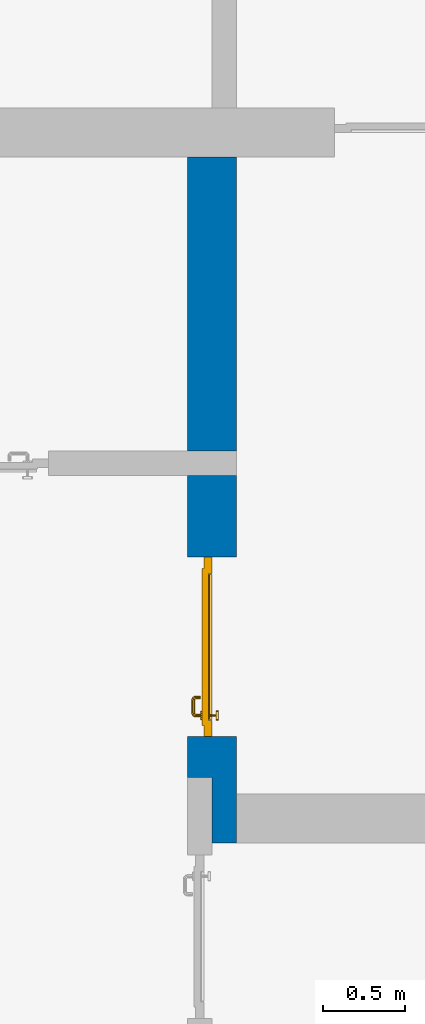
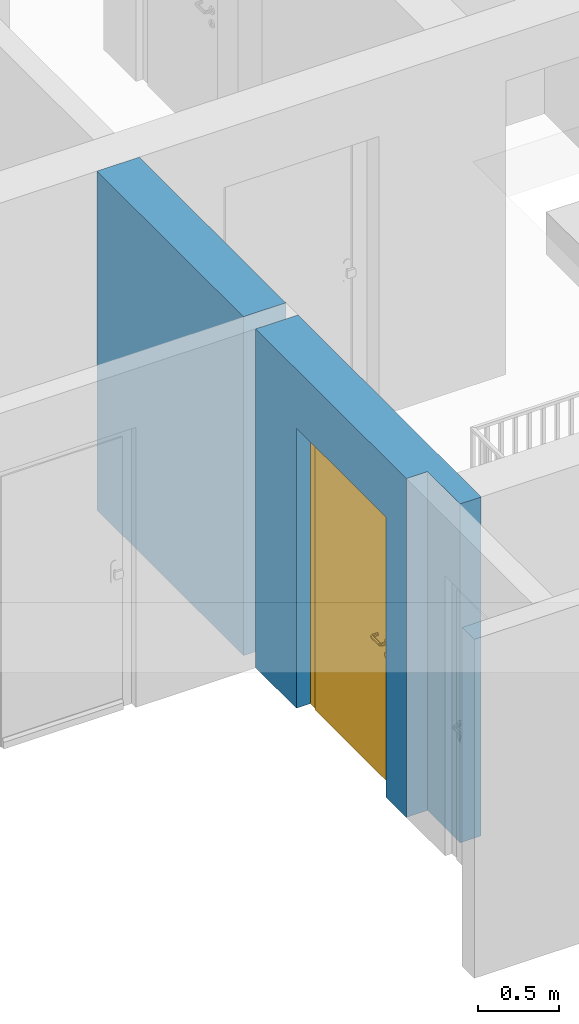
# One storey, part 10 of 48: 1 door, 1 wall, 1 opening.
"""IFC4 building model written with IfcOpenShell, lengths in metres."""

from ifc_helpers import new_model, entity, si_unit, converted_unit, derived_unit, direction, frame, origin_with_axes, place, context, subcontext, project, spatial, polygons, source, transform, mapped, material, type_object, element, fill, save


model = new_model("IFC4")

# Units and contexts
model_context = context("Model", 3, precision=1e-05, world=origin_with_axes(), true_north=direction((0.0, 1.0)))
body_context = subcontext(model_context, "Body", "Model", "MODEL_VIEW")
ifc_project = project(units=[si_unit("LENGTHUNIT", "METRE"), si_unit("AREAUNIT", "SQUARE_METRE"), si_unit("VOLUMEUNIT", "CUBIC_METRE"), converted_unit("PLANEANGLEUNIT", "DEGREE", entity("IfcPlaneAngleMeasure", 0.0174532925199), si_unit("PLANEANGLEUNIT", "RADIAN"), dimensions=[0, 0, 0, 0, 0, 0, 0]), converted_unit("TIMEUNIT", "Year", entity("IfcTimeMeasure", 31556926.0), si_unit("TIMEUNIT", "SECOND"), dimensions=[0, 0, 1, 0, 0, 0, 0]), si_unit("MASSUNIT", "GRAM", prefix="KILO"), si_unit("THERMODYNAMICTEMPERATUREUNIT", "DEGREE_CELSIUS"), si_unit("LUMINOUSINTENSITYUNIT", "LUMEN"), si_unit("ENERGYUNIT", "JOULE", prefix="MEGA"), derived_unit("THERMALCONDUCTANCEUNIT", [(si_unit("POWERUNIT", "WATT"), 1), (si_unit("LENGTHUNIT", "METRE"), -1), (si_unit("THERMODYNAMICTEMPERATUREUNIT", "KELVIN"), -1)]), derived_unit("SPECIFICHEATCAPACITYUNIT", [(si_unit("ENERGYUNIT", "JOULE"), 1), (si_unit("MASSUNIT", "GRAM", prefix="KILO"), -1), (si_unit("THERMODYNAMICTEMPERATUREUNIT", "KELVIN"), -1)]), derived_unit("MASSDENSITYUNIT", [(si_unit("MASSUNIT", "GRAM", prefix="KILO"), 1), (si_unit("VOLUMEUNIT", "CUBIC_METRE"), -1)])], contexts=[model_context])

# Site, building, storey
site_placement = place(None, origin_with_axes())
site = spatial("IfcSite", under=ifc_project, at=site_placement, CompositionType="ELEMENT")
building_placement = place(site_placement, origin_with_axes())
building = spatial("IfcBuilding", under=site, at=building_placement, CompositionType="ELEMENT")
storey_placement = place(building_placement, frame((0.0, 0.0, 3.4), z_axis=(0.0, 0.0, 1.0), x_axis=(1.0, 0.0, 0.0)))
storey = spatial("IfcBuildingStorey", under=building, at=storey_placement, Name="1. Geschoss", CompositionType="ELEMENT", Elevation=3.4)

# Wall, opening, door
ifc_material = material()
wall_type = type_object("IfcWallType", Name="300", PredefinedType="NOTDEFINED")
wall_placement = place(storey_placement, frame((-5.2421993804, -2.52881223104, 0.0), z_axis=(0.0, 0.0, 1.0), x_axis=(0.0, 1.0, 0.0)))
wall = element("IfcWall", 1, at=wall_placement, inside=storey, type_object=wall_type, material=ifc_material, Name="Wand-001", PredefinedType="NOTDEFINED", context=body_context, shape_type="Tessellation", body=[
    polygons([(0.35, -0.15, 2.1), (1.45, -0.15, 2.1), (1.45, -0.3, 2.1), (0.35, -0.3, 2.1), (0.35, 0.0, 2.1), (1.45, 0.0, 2.1), (1.45, -0.15, 0.0), (1.45, -0.3, 0.0), (1.95, -0.3, 2.54), (-0.3, -0.3, 2.54), (-0.3, -0.3, 0.0), (0.35, -0.3, 0.0), (1.95, -0.3, 0.0), (0.35, -0.15, 0.0), (0.35, 0.0, 0.0), (0.1, 0.0, 0.0), (0.1, 0.0, 2.54), (1.95, 0.0, 2.54), (1.95, 0.0, 0.0), (1.45, 0.0, 0.0), (-0.3, -0.15, 2.54), (0.1, -0.15, 2.54), (-0.3, -0.15, 0.0), (0.1, -0.15, 0.0)], [[[1, 2, 3, 4]], [[2, 1, 5, 6]], [[2, 7, 8, 3]], [[9, 10, 11, 12, 4, 3, 8, 13]], [[14, 1, 4, 12]], [[1, 14, 15, 5]], [[5, 15, 16, 17, 18, 19, 20, 6]], [[7, 2, 6, 20]], [[7, 20, 19, 13, 8]], [[21, 10, 9, 18, 17, 22]], [[21, 23, 11, 10]], [[15, 14, 12, 11, 23, 24, 16]], [[9, 13, 19, 18]], [[17, 16, 24, 22]], [[22, 24, 23, 21]]], closed=True),
    polygons([(3.9, 0.0, 0.0), (3.9, 0.0, 2.54), (3.9, -0.3, 2.54), (3.9, -0.3, 0.0), (2.1, 0.0, 0.0), (2.1, 0.0, 2.54), (2.1, -0.3, 2.54), (2.1, -0.3, 0.0)], [[[1, 2, 3, 4]], [[5, 6, 2, 1]], [[6, 7, 3, 2]], [[4, 3, 7, 8]], [[5, 1, 4, 8]], [[8, 7, 6, 5]]], closed=True),
])
opening_placement = place(wall_placement, frame((0.9, 0.0, 0.0), z_axis=(0.0, 0.0, 1.0), x_axis=(1.0, 0.0, 0.0)))
opening = element("IfcOpeningElement", 2, at=opening_placement, cuts=wall, context=body_context, identifier="Reference", shape_type="Tessellation", body=[
    polygons([(0.55, -0.15, 0.0), (0.55, -0.15, 2.1), (0.55, -0.301, 2.1), (0.55, -0.301, 0.0), (0.55, 0.001, 0.0), (0.55, 0.001, 2.1), (-0.55, -0.15, 2.1), (-0.55, -0.301, 2.1), (-0.55, 0.001, 2.1), (-0.55, -0.301, 0.0), (-0.55, -0.15, 0.0), (-0.55, 0.001, 0.0)], [[[1, 2, 3, 4]], [[2, 1, 5, 6]], [[7, 8, 3, 2, 6, 9]], [[8, 10, 4, 3]], [[1, 4, 10, 11, 12, 5]], [[6, 5, 12, 9]], [[7, 11, 10, 8]], [[11, 7, 9, 12]]], closed=True),
])
door_type = type_object("IfcDoorType", Name="Eingang 01 1-Fl 26", OperationType="SINGLE_SWING_RIGHT", PredefinedType="DOOR")
shared_shape = source(origin_with_axes(), body_context, "Body", "Tessellation", [
    polygons([(0.55, -0.05, 0.0), (0.55, -0.03, 0.0), (0.55, -0.03, 2.1), (0.55, -0.05, 2.1), (0.45, -0.05, 0.0), (0.45, -0.03, 0.0), (0.45, -0.03, 2.0), (0.1301, -0.03, 2.0), (0.0001, -0.03, 2.0), (-0.45, -0.03, 2.0), (-0.45, -0.03, 0.0), (-0.55, -0.03, 0.0), (-0.55, -0.03, 2.1), (-0.55, -0.05, 2.1), (-0.55, -0.05, 0.0), (-0.45, -0.05, 0.0), (-0.45, -0.05, 2.0), (0.0001, -0.05, 2.0), (0.1301, -0.05, 2.0), (0.45, -0.05, 2.0)], [[[1, 2, 3, 4]], [[5, 6, 2, 1]], [[2, 6, 7, 8, 9, 10, 11, 12, 13, 3]], [[4, 3, 13, 14]], [[1, 4, 14, 15, 16, 17, 18, 19, 20, 5]], [[20, 7, 6, 5]], [[19, 8, 7, 20]], [[18, 9, 8, 19]], [[17, 10, 9, 18]], [[16, 11, 10, 17]], [[15, 12, 11, 16]], [[14, 13, 12, 15]]], closed=True),
    polygons([(0.55, -0.03, 0.0), (0.55, 0.0, 0.0), (0.55, 0.0, 2.1), (0.55, -0.03, 2.1), (0.48, -0.03, 0.0), (0.48, 0.0, 0.0), (0.48, 0.0, 2.03), (0.1001, 0.0, 2.03), (0.0301, 0.0, 2.03), (-0.48, 0.0, 2.03), (-0.48, 0.0, 0.0), (-0.55, 0.0, 0.0), (-0.55, 0.0, 2.1), (-0.55, -0.03, 2.1), (-0.55, -0.03, 0.0), (-0.48, -0.03, 0.0), (-0.48, -0.03, 2.03), (0.0301, -0.03, 2.03), (0.1001, -0.03, 2.03), (0.48, -0.03, 2.03)], [[[1, 2, 3, 4]], [[5, 6, 2, 1]], [[2, 6, 7, 8, 9, 10, 11, 12, 13, 3]], [[4, 3, 13, 14]], [[1, 4, 14, 15, 16, 17, 18, 19, 20, 5]], [[20, 7, 6, 5]], [[19, 8, 7, 20]], [[18, 9, 8, 19]], [[17, 10, 9, 18]], [[16, 11, 10, 17]], [[15, 12, 11, 16]], [[14, 13, 12, 15]]], closed=True),
    polygons([(0.48, 0.01, 0.0), (-0.48, 0.01, 0.0), (-0.48, 0.01, 2.03), (0.48, 0.01, 2.03), (0.48, -0.03, 0.0), (-0.48, -0.03, 0.0), (-0.48, -0.03, 2.03), (0.48, -0.03, 2.03)], [[[1, 2, 3, 4]], [[2, 1, 5, 6]], [[3, 2, 6, 7]], [[4, 3, 7, 8]], [[1, 4, 8, 5]], [[6, 5, 8, 7]]], closed=True),
    polygons([(0.445, -0.05, 0.0), (0.445, -0.05, 0.05), (-0.445, -0.05, 0.05), (-0.445, -0.05, 0.0), (0.445, -0.03, 0.0), (0.445, -0.03, 0.07), (0.445, -0.035, 0.07), (-0.445, -0.035, 0.07), (-0.445, -0.03, 0.07), (-0.445, -0.03, 0.0)], [[[1, 2, 3, 4]], [[1, 5, 6, 7, 2]], [[2, 7, 8, 3]], [[4, 3, 8, 9, 10]], [[5, 1, 4, 10]], [[6, 5, 10, 9]], [[7, 6, 9, 8]]], closed=True),
    polygons([(-0.4335, 0.02, 1.0733826859), (-0.4335, 0.0199, 1.0733826859), (-0.42, 0.0199, 1.077), (-0.42, 0.02, 1.077), (-0.443382685902, 0.02, 1.0635), (-0.443382685902, 0.0199, 1.0635), (-0.4335, 0.0101, 1.0733826859), (-0.42, 0.0101, 1.077), (-0.4065, 0.0199, 1.0733826859), (-0.4065, 0.02, 1.0733826859), (-0.396617314098, 0.02, 1.0635), (-0.393, 0.02, 1.05), (-0.396617314098, 0.02, 1.0365), (-0.4065, 0.02, 1.0266173141), (-0.42, 0.02, 1.023), (-0.4335, 0.02, 1.0266173141), (-0.443382685902, 0.02, 1.0365), (-0.447, 0.02, 1.05), (-0.447, 0.0199, 1.05), (-0.443382685902, 0.0101, 1.0635), (-0.4335, 0.01, 1.0733826859), (-0.42, 0.01, 1.077), (-0.4065, 0.0101, 1.0733826859), (-0.396617314098, 0.0199, 1.0635), (-0.393, 0.0199, 1.05), (-0.396617314098, 0.0199, 1.0365), (-0.4065, 0.0199, 1.0266173141), (-0.42, 0.0199, 1.023), (-0.4335, 0.0199, 1.0266173141), (-0.443382685902, 0.0199, 1.0365), (-0.447, 0.0101, 1.05), (-0.443382685902, 0.01, 1.0635), (-0.447, 0.01, 1.05), (-0.443382685902, 0.01, 1.0365), (-0.4335, 0.01, 1.0266173141), (-0.42, 0.01, 1.023), (-0.4065, 0.01, 1.0266173141), (-0.396617314098, 0.01, 1.0365), (-0.393, 0.01, 1.05), (-0.396617314098, 0.01, 1.0635), (-0.4065, 0.01, 1.0733826859), (-0.396617314098, 0.0101, 1.0635), (-0.393, 0.0101, 1.05), (-0.396617314098, 0.0101, 1.0365), (-0.4065, 0.0101, 1.0266173141), (-0.42, 0.0101, 1.023), (-0.4335, 0.0101, 1.0266173141), (-0.443382685902, 0.0101, 1.0365)], [[[1, 2, 3, 4]], [[5, 6, 2, 1]], [[2, 7, 8, 3]], [[4, 3, 9, 10]], [[4, 10, 11, 12, 13, 14, 15, 16, 17, 18, 5, 1]], [[18, 19, 6, 5]], [[6, 20, 7, 2]], [[7, 21, 22, 8]], [[3, 8, 23, 9]], [[10, 9, 24, 11]], [[11, 24, 25, 12]], [[12, 25, 26, 13]], [[13, 26, 27, 14]], [[14, 27, 28, 15]], [[15, 28, 29, 16]], [[16, 29, 30, 17]], [[17, 30, 19, 18]], [[19, 31, 20, 6]], [[20, 32, 21, 7]], [[22, 21, 32, 33, 34, 35, 36, 37, 38, 39, 40, 41]], [[8, 22, 41, 23]], [[9, 23, 42, 24]], [[24, 42, 43, 25]], [[25, 43, 44, 26]], [[26, 44, 45, 27]], [[27, 45, 46, 28]], [[28, 46, 47, 29]], [[29, 47, 48, 30]], [[30, 48, 31, 19]], [[31, 33, 32, 20]], [[48, 34, 33, 31]], [[47, 35, 34, 48]], [[46, 36, 35, 47]], [[45, 37, 36, 46]], [[44, 38, 37, 45]], [[43, 39, 38, 44]], [[42, 40, 39, 43]], [[23, 41, 40, 42]]], closed=True),
    polygons([(-0.412532169224, 0.019, 0.959692280177), (-0.415, 0.019, 0.9544), (-0.415, 0.019, 0.952886751346), (-0.397569942042, 0.019, 0.96295), (-0.40705, 0.019, 0.972430057958), (-0.413279754556, 0.019, 0.961639806549), (-0.412532169224, 0.02, 0.959692280177), (-0.415, 0.02, 0.9544), (-0.415, 0.02, 0.952886751346), (-0.415, 0.02, 0.95), (-0.415, 0.02, 0.947113248654), (-0.415, 0.02, 0.941339745962), (-0.415, 0.02, 0.9375), (-0.415, 0.019, 0.9375), (-0.415, 0.019, 0.941339745962), (-0.415, 0.019, 0.947113248654), (-0.415, 0.019, 0.95), (-0.3941, 0.019, 0.95), (-0.397483339502, 0.019, 0.963), (-0.407, 0.019, 0.972516660498), (-0.414624817685, 0.019, 0.965143815798), (-0.42, 0.019, 0.9759), (-0.42, 0.019, 0.967425445323), (-0.414624817685, 0.02, 0.965143815798), (-0.413279754556, 0.02, 0.961639806549), (-0.40655, 0.02, 0.973296083362), (-0.396703916638, 0.02, 0.96345), (-0.3931, 0.02, 0.95), (-0.396703916638, 0.02, 0.93655), (-0.40655, 0.02, 0.926703916638), (-0.42, 0.02, 0.9231), (-0.42, 0.02, 0.9325), (-0.416464466094, 0.02, 0.933964466094), (-0.416464466094, 0.019, 0.933964466094), (-0.40705, 0.019, 0.927569942042), (-0.42, 0.019, 0.9325), (-0.42, 0.019, 0.9241), (-0.397569942042, 0.019, 0.93705), (-0.394, 0.019, 0.95), (-0.397483339502, 0.0189, 0.963), (-0.407, 0.0189, 0.972516660498), (-0.42, 0.019, 0.976), (-0.425375182315, 0.019, 0.965143815798), (-0.43295, 0.019, 0.972430057958), (-0.426720245444, 0.019, 0.961639806549), (-0.42, 0.02, 0.967425445323), (-0.42, 0.02, 0.9769), (-0.396617314098, 0.02, 0.9635), (-0.4065, 0.02, 0.973382685902), (-0.393, 0.02, 0.95), (-0.396617314098, 0.02, 0.9365), (-0.4065, 0.02, 0.926617314098), (-0.43345, 0.02, 0.926703916638), (-0.425, 0.02, 0.941339745962), (-0.425, 0.02, 0.9375), (-0.423535533906, 0.02, 0.933964466094), (-0.42, 0.02, 0.923), (-0.423535533906, 0.019, 0.933964466094), (-0.425, 0.019, 0.9375), (-0.425, 0.019, 0.941339745962), (-0.43295, 0.019, 0.927569942042), (-0.42, 0.019, 0.924), (-0.407, 0.019, 0.927483339502), (-0.397483339502, 0.019, 0.937), (-0.394, 0.0189, 0.95), (-0.397483339502, 0.0101, 0.963), (-0.407, 0.0101, 0.972516660498), (-0.42, 0.0189, 0.976), (-0.433, 0.019, 0.972516660498), (-0.425375182315, 0.02, 0.965143815798), (-0.427467830776, 0.019, 0.959692280177), (-0.442430057958, 0.019, 0.96295), (-0.425, 0.019, 0.952886751346), (-0.425, 0.019, 0.9544), (-0.427467830776, 0.02, 0.959692280177), (-0.426720245444, 0.02, 0.961639806549), (-0.43345, 0.02, 0.973296083362), (-0.42, 0.02, 0.977), (-0.396617314098, 0.0199, 0.9635), (-0.4065, 0.0199, 0.973382685902), (-0.393, 0.0199, 0.95), (-0.396617314098, 0.0199, 0.9365), (-0.4065, 0.0199, 0.926617314098), (-0.443296083362, 0.02, 0.93655), (-0.425, 0.02, 0.947113248654), (-0.425, 0.02, 0.9544), (-0.425, 0.019, 0.95), (-0.425, 0.019, 0.947113248654), (-0.425, 0.02, 0.95), (-0.425, 0.02, 0.952886751346), (-0.4335, 0.02, 0.926617314098), (-0.42, 0.0199, 0.923), (-0.442430057958, 0.019, 0.93705), (-0.433, 0.019, 0.927483339502), (-0.42, 0.0189, 0.924), (-0.407, 0.0189, 0.927483339502), (-0.397483339502, 0.0189, 0.937), (-0.394, 0.0101, 0.95), (-0.397483339502, 0.01, 0.963), (-0.407, 0.01, 0.972516660498), (-0.42, 0.0101, 0.976), (-0.433, 0.0189, 0.972516660498), (-0.442516660498, 0.019, 0.963), (-0.4459, 0.019, 0.95), (-0.443296083362, 0.02, 0.96345), (-0.4335, 0.02, 0.973382685902), (-0.42, 0.0199, 0.977), (-0.396617314098, 0.0101, 0.9635), (-0.4065, 0.0101, 0.973382685902), (-0.393, 0.0101, 0.95), (-0.396617314098, 0.0101, 0.9365), (-0.4065, 0.0101, 0.926617314098), (-0.443382685902, 0.02, 0.9365), (-0.4469, 0.02, 0.95), (-0.4335, 0.0199, 0.926617314098), (-0.42, 0.0101, 0.923), (-0.442516660498, 0.019, 0.937), (-0.433, 0.0189, 0.927483339502), (-0.42, 0.0101, 0.924), (-0.407, 0.0101, 0.927483339502), (-0.397483339502, 0.0101, 0.937), (-0.394, 0.01, 0.95), (-0.397396736961, 0.01, 0.96305), (-0.40695, 0.01, 0.972603263039), (-0.42, 0.01, 0.976), (-0.433, 0.0101, 0.972516660498), (-0.442516660498, 0.0189, 0.963), (-0.446, 0.019, 0.95), (-0.443382685902, 0.02, 0.9635), (-0.4335, 0.0199, 0.973382685902), (-0.42, 0.0101, 0.977), (-0.396617314098, 0.01, 0.9635), (-0.4065, 0.01, 0.973382685902), (-0.393, 0.01, 0.95), (-0.396617314098, 0.01, 0.9365), (-0.4065, 0.01, 0.926617314098), (-0.447, 0.02, 0.95), (-0.443382685902, 0.0199, 0.9365), (-0.4335, 0.0101, 0.926617314098), (-0.42, 0.01, 0.923), (-0.442516660498, 0.0189, 0.937), (-0.433, 0.0101, 0.927483339502), (-0.42, 0.01, 0.924), (-0.407, 0.01, 0.927483339502), (-0.397483339502, 0.01, 0.937), (-0.3939, 0.01, 0.95), (-0.396703916638, 0.01, 0.96345), (-0.40655, 0.01, 0.973296083362), (-0.42, 0.01, 0.9761), (-0.433, 0.01, 0.972516660498), (-0.442516660498, 0.0101, 0.963), (-0.446, 0.0189, 0.95), (-0.443382685902, 0.0199, 0.9635), (-0.4335, 0.0101, 0.973382685902), (-0.42, 0.01, 0.977), (-0.3931, 0.01, 0.95), (-0.396703916638, 0.01, 0.93655), (-0.40655, 0.01, 0.926703916638), (-0.447, 0.0199, 0.95), (-0.443382685902, 0.0101, 0.9365), (-0.4335, 0.01, 0.926617314098), (-0.42, 0.01, 0.9231), (-0.442516660498, 0.0101, 0.937), (-0.433, 0.01, 0.927483339502), (-0.42, 0.01, 0.9239), (-0.40695, 0.01, 0.927396736961), (-0.397396736961, 0.01, 0.93695), (-0.42, 0.01, 0.9769), (-0.43305, 0.01, 0.972603263039), (-0.442516660498, 0.01, 0.963), (-0.446, 0.0101, 0.95), (-0.443382685902, 0.0101, 0.9635), (-0.4335, 0.01, 0.973382685902), (-0.447, 0.0101, 0.95), (-0.443382685902, 0.01, 0.9365), (-0.43345, 0.01, 0.926703916638), (-0.442516660498, 0.01, 0.937), (-0.43305, 0.01, 0.927396736961), (-0.43345, 0.01, 0.973296083362), (-0.442603263039, 0.01, 0.96305), (-0.446, 0.01, 0.95), (-0.443382685902, 0.01, 0.9635), (-0.447, 0.01, 0.95), (-0.443296083362, 0.01, 0.93655), (-0.442603263039, 0.01, 0.93695), (-0.443296083362, 0.01, 0.96345), (-0.4461, 0.01, 0.95), (-0.4469, 0.01, 0.95)], [[[1, 2, 3, 4, 5, 6]], [[2, 1, 7, 8]], [[2, 8, 9, 10, 11, 12, 13, 14, 15, 16, 17, 3]], [[17, 18, 4, 3]], [[4, 19, 20, 5]], [[21, 6, 5, 22, 23]], [[1, 6, 21, 24, 25, 7]], [[7, 25, 26, 27, 9, 8]], [[9, 27, 28, 10]], [[10, 28, 29, 11]], [[11, 29, 30, 12]], [[31, 32, 33, 13, 12, 30]], [[14, 13, 33, 34]], [[35, 15, 14, 34, 36, 37]], [[15, 35, 38, 16]], [[16, 38, 18, 17]], [[18, 39, 19, 4]], [[19, 40, 41, 20]], [[5, 20, 42, 22]], [[43, 23, 22, 44, 45]], [[21, 23, 46, 24]], [[24, 46, 47, 26, 25]], [[48, 27, 26, 49]], [[50, 28, 27, 48]], [[51, 29, 28, 50]], [[52, 30, 29, 51]], [[53, 54, 55, 56, 32, 31]], [[34, 33, 32, 36]], [[57, 31, 30, 52]], [[37, 36, 58, 59, 60, 61]], [[37, 62, 63, 35]], [[35, 63, 64, 38]], [[38, 64, 39, 18]], [[39, 65, 40, 19]], [[40, 66, 67, 41]], [[20, 41, 68, 42]], [[22, 42, 69, 44]], [[23, 43, 70, 46]], [[71, 45, 44, 72, 73, 74]], [[43, 45, 71, 75, 76, 70]], [[70, 76, 77, 47, 46]], [[49, 26, 47, 78]], [[79, 48, 49, 80]], [[81, 50, 48, 79]], [[82, 51, 50, 81]], [[83, 52, 51, 82]], [[54, 53, 84, 85]], [[86, 74, 73, 87, 88, 60, 59, 55, 54, 85, 89, 90]], [[58, 56, 55, 59]], [[36, 32, 56, 58]], [[91, 53, 31, 57]], [[92, 57, 52, 83]], [[88, 93, 61, 60]], [[61, 94, 62, 37]], [[62, 95, 96, 63]], [[63, 96, 97, 64]], [[64, 97, 65, 39]], [[65, 98, 66, 40]], [[66, 99, 100, 67]], [[41, 67, 101, 68]], [[42, 68, 102, 69]], [[44, 69, 103, 72]], [[73, 72, 104, 87]], [[71, 74, 86, 75]], [[75, 86, 90, 105, 77, 76]], [[78, 47, 77, 106]], [[80, 49, 78, 107]], [[108, 79, 80, 109]], [[110, 81, 79, 108]], [[111, 82, 81, 110]], [[112, 83, 82, 111]], [[113, 84, 53, 91]], [[85, 84, 114, 89]], [[87, 104, 93, 88]], [[89, 114, 105, 90]], [[115, 91, 57, 92]], [[116, 92, 83, 112]], [[93, 117, 94, 61]], [[94, 118, 95, 62]], [[95, 119, 120, 96]], [[96, 120, 121, 97]], [[97, 121, 98, 65]], [[98, 122, 99, 66]], [[99, 123, 124, 100]], [[67, 100, 125, 101]], [[68, 101, 126, 102]], [[69, 102, 127, 103]], [[72, 103, 128, 104]], [[106, 77, 105, 129]], [[107, 78, 106, 130]], [[109, 80, 107, 131]], [[132, 108, 109, 133]], [[134, 110, 108, 132]], [[135, 111, 110, 134]], [[136, 112, 111, 135]], [[137, 114, 84, 113]], [[138, 113, 91, 115]], [[104, 128, 117, 93]], [[129, 105, 114, 137]], [[139, 115, 92, 116]], [[140, 116, 112, 136]], [[117, 141, 118, 94]], [[118, 142, 119, 95]], [[119, 143, 144, 120]], [[120, 144, 145, 121]], [[121, 145, 122, 98]], [[122, 146, 123, 99]], [[123, 147, 148, 124]], [[100, 124, 149, 125]], [[101, 125, 150, 126]], [[102, 126, 151, 127]], [[103, 127, 152, 128]], [[130, 106, 129, 153]], [[131, 107, 130, 154]], [[133, 109, 131, 155]], [[147, 132, 133, 148]], [[156, 134, 132, 147]], [[157, 135, 134, 156]], [[158, 136, 135, 157]], [[159, 137, 113, 138]], [[160, 138, 115, 139]], [[128, 152, 141, 117]], [[153, 129, 137, 159]], [[161, 139, 116, 140]], [[162, 140, 136, 158]], [[141, 163, 142, 118]], [[142, 164, 143, 119]], [[143, 165, 166, 144]], [[144, 166, 167, 145]], [[145, 167, 146, 122]], [[146, 156, 147, 123]], [[124, 148, 168, 149]], [[125, 149, 169, 150]], [[126, 150, 170, 151]], [[127, 151, 171, 152]], [[154, 130, 153, 172]], [[155, 131, 154, 173]], [[148, 133, 155, 168]], [[167, 157, 156, 146]], [[166, 158, 157, 167]], [[174, 159, 138, 160]], [[175, 160, 139, 161]], [[152, 171, 163, 141]], [[172, 153, 159, 174]], [[176, 161, 140, 162]], [[165, 162, 158, 166]], [[163, 177, 164, 142]], [[164, 178, 165, 143]], [[149, 168, 179, 169]], [[150, 169, 180, 170]], [[151, 170, 181, 171]], [[173, 154, 172, 182]], [[168, 155, 173, 179]], [[183, 174, 160, 175]], [[184, 175, 161, 176]], [[171, 181, 177, 163]], [[182, 172, 174, 183]], [[178, 176, 162, 165]], [[177, 185, 178, 164]], [[169, 179, 186, 180]], [[170, 180, 187, 181]], [[179, 173, 182, 186]], [[188, 183, 175, 184]], [[185, 184, 176, 178]], [[181, 187, 185, 177]], [[186, 182, 183, 188]], [[180, 186, 188, 187]], [[187, 188, 184, 185]]], closed=True),
    polygons([(-0.43, 0.02, 1.05), (-0.43, 0.0509849140336, 1.05), (-0.427071067812, 0.050696439392, 1.04292893219), (-0.427071067812, 0.02, 1.04292893219), (-0.427071067812, 0.02, 1.05707106781), (-0.427071067812, 0.050696439392, 1.05707106781), (-0.428277987014, 0.0596420579258, 1.05), (-0.425518993221, 0.0584992452783, 1.04292893219), (-0.42, 0.05, 1.04), (-0.42, 0.02, 1.04), (-0.42, 0.02, 1.06), (-0.42, 0.05, 1.06), (-0.425518993221, 0.0584992452783, 1.05707106781), (-0.422816199938, 0.0678161999379, 1.05), (-0.420704557509, 0.0657045575088, 1.04292893219), (-0.418858192988, 0.0557402514855, 1.04), (-0.412928932188, 0.049303560608, 1.04292893219), (-0.412928932188, 0.02, 1.04292893219), (-0.412928932188, 0.02, 1.05707106781), (-0.412928932188, 0.049303560608, 1.05707106781), (-0.418858192988, 0.0557402514855, 1.06), (-0.420704557509, 0.0657045575088, 1.05707106781), (-0.414642057926, 0.0732779870137, 1.05), (-0.413499245278, 0.0705189932208, 1.04292893219), (-0.415606601718, 0.0606066017178, 1.04), (-0.412197392755, 0.0529812576926, 1.04292893219), (-0.41, 0.0490150859664, 1.05), (-0.41, 0.02, 1.05), (-0.412197392755, 0.0529812576926, 1.05707106781), (-0.415606601718, 0.0606066017178, 1.06), (-0.413499245278, 0.0705189932208, 1.05707106781), (-0.405984914034, 0.075, 1.05), (-0.405696439392, 0.0720710678119, 1.04292893219), (-0.410740251485, 0.0638581929877, 1.04), (-0.410508645927, 0.0555086459268, 1.04292893219), (-0.409438398962, 0.0518384450452, 1.05), (-0.410508645927, 0.0555086459268, 1.05707106781), (-0.410740251485, 0.0638581929877, 1.06), (-0.405696439392, 0.0720710678119, 1.05707106781), (-0.324015085966, 0.075, 1.05), (-0.324303560608, 0.0720710678119, 1.04292893219), (-0.405, 0.065, 1.04), (-0.407981257693, 0.0571973927545, 1.04292893219), (-0.408397003498, 0.0533970034977, 1.05), (-0.407981257693, 0.0571973927545, 1.05707106781), (-0.405, 0.065, 1.06), (-0.324303560608, 0.0720710678119, 1.05707106781), (-0.315357942074, 0.0732779870137, 1.05), (-0.316500754722, 0.0705189932208, 1.04292893219), (-0.325, 0.065, 1.04), (-0.404303560608, 0.0579289321881, 1.04292893219), (-0.406838445045, 0.0544383989617, 1.05), (-0.404303560608, 0.0579289321881, 1.05707106781), (-0.325, 0.065, 1.06), (-0.316500754722, 0.0705189932208, 1.05707106781), (-0.307183800062, 0.0678161999379, 1.05), (-0.309295442491, 0.0657045575088, 1.04292893219), (-0.319259748515, 0.0638581929877, 1.04), (-0.325696439392, 0.0579289321881, 1.04292893219), (-0.404015085966, 0.055, 1.05), (-0.325696439392, 0.0579289321881, 1.05707106781), (-0.319259748515, 0.0638581929877, 1.06), (-0.309295442491, 0.0657045575088, 1.05707106781), (-0.301722012986, 0.0596420579258, 1.05), (-0.304481006779, 0.0584992452783, 1.04292893219), (-0.314393398282, 0.0606066017178, 1.04), (-0.322018742307, 0.0571973927545, 1.04292893219), (-0.325984914034, 0.055, 1.05), (-0.322018742307, 0.0571973927545, 1.05707106781), (-0.314393398282, 0.0606066017178, 1.06), (-0.304481006779, 0.0584992452783, 1.05707106781), (-0.3, 0.0509849140336, 1.05), (-0.302928932188, 0.050696439392, 1.04292893219), (-0.311141807012, 0.0557402514855, 1.04), (-0.319491354073, 0.0555086459268, 1.04292893219), (-0.323161554955, 0.0544383989617, 1.05), (-0.319491354073, 0.0555086459268, 1.05707106781), (-0.311141807012, 0.0557402514855, 1.06), (-0.302928932188, 0.050696439392, 1.05707106781), (-0.3, 0.02, 1.05), (-0.302928932188, 0.02, 1.04292893219), (-0.31, 0.05, 1.04), (-0.317802607245, 0.0529812576926, 1.04292893219), (-0.321602996502, 0.0533970034977, 1.05), (-0.317802607245, 0.0529812576926, 1.05707106781), (-0.31, 0.05, 1.06), (-0.302928932188, 0.02, 1.05707106781), (-0.31, 0.02, 1.06), (-0.317071067812, 0.02, 1.05707106781), (-0.32, 0.02, 1.05), (-0.317071067812, 0.02, 1.04292893219), (-0.31, 0.02, 1.04), (-0.317071067812, 0.049303560608, 1.04292893219), (-0.320561601038, 0.0518384450452, 1.05), (-0.317071067812, 0.049303560608, 1.05707106781), (-0.32, 0.0490150859664, 1.05)], [[[1, 2, 3, 4]], [[5, 6, 2, 1]], [[2, 7, 8, 3]], [[4, 3, 9, 10]], [[11, 12, 6, 5]], [[6, 13, 7, 2]], [[7, 14, 15, 8]], [[3, 8, 16, 9]], [[10, 9, 17, 18]], [[19, 20, 12, 11]], [[12, 21, 13, 6]], [[13, 22, 14, 7]], [[14, 23, 24, 15]], [[8, 15, 25, 16]], [[9, 16, 26, 17]], [[18, 17, 27, 28]], [[28, 27, 20, 19]], [[20, 29, 21, 12]], [[21, 30, 22, 13]], [[22, 31, 23, 14]], [[23, 32, 33, 24]], [[15, 24, 34, 25]], [[16, 25, 35, 26]], [[17, 26, 36, 27]], [[27, 36, 29, 20]], [[29, 37, 30, 21]], [[30, 38, 31, 22]], [[31, 39, 32, 23]], [[32, 40, 41, 33]], [[24, 33, 42, 34]], [[25, 34, 43, 35]], [[26, 35, 44, 36]], [[36, 44, 37, 29]], [[37, 45, 38, 30]], [[38, 46, 39, 31]], [[39, 47, 40, 32]], [[40, 48, 49, 41]], [[33, 41, 50, 42]], [[34, 42, 51, 43]], [[35, 43, 52, 44]], [[44, 52, 45, 37]], [[45, 53, 46, 38]], [[46, 54, 47, 39]], [[47, 55, 48, 40]], [[48, 56, 57, 49]], [[41, 49, 58, 50]], [[42, 50, 59, 51]], [[43, 51, 60, 52]], [[52, 60, 53, 45]], [[53, 61, 54, 46]], [[54, 62, 55, 47]], [[55, 63, 56, 48]], [[56, 64, 65, 57]], [[49, 57, 66, 58]], [[50, 58, 67, 59]], [[51, 59, 68, 60]], [[60, 68, 61, 53]], [[61, 69, 62, 54]], [[62, 70, 63, 55]], [[63, 71, 64, 56]], [[64, 72, 73, 65]], [[57, 65, 74, 66]], [[58, 66, 75, 67]], [[59, 67, 76, 68]], [[68, 76, 69, 61]], [[69, 77, 70, 62]], [[70, 78, 71, 63]], [[71, 79, 72, 64]], [[72, 80, 81, 73]], [[65, 73, 82, 74]], [[66, 74, 83, 75]], [[67, 75, 84, 76]], [[76, 84, 77, 69]], [[77, 85, 78, 70]], [[78, 86, 79, 71]], [[79, 87, 80, 72]], [[80, 87, 88, 89, 90, 91, 92, 81]], [[73, 81, 92, 82]], [[74, 82, 93, 83]], [[75, 83, 94, 84]], [[84, 94, 85, 77]], [[85, 95, 86, 78]], [[86, 88, 87, 79]], [[95, 89, 88, 86]], [[96, 90, 89, 95]], [[93, 91, 90, 96]], [[82, 92, 91, 93]], [[83, 93, 96, 94]], [[94, 96, 95, 85]]], closed=False),
    polygons([(-0.414696699141, -0.035, 1.04469669914), (-0.42, -0.035, 1.0425), (-0.425303300859, -0.035, 1.04469669914), (-0.4275, -0.035, 1.05), (-0.425303300859, -0.035, 1.05530330086), (-0.42, -0.035, 1.0575), (-0.414696699141, -0.035, 1.05530330086), (-0.4125, -0.035, 1.05), (-0.414696699141, -0.075, 1.04469669914), (-0.42, -0.075, 1.0425), (-0.425303300859, -0.075, 1.04469669914), (-0.4275, -0.075, 1.05), (-0.425303300859, -0.075, 1.05530330086), (-0.42, -0.075, 1.0575), (-0.414696699141, -0.075, 1.05530330086), (-0.4125, -0.075, 1.05)], [[[1, 2, 3, 4, 5, 6, 7, 8]], [[2, 1, 9, 10]], [[3, 2, 10, 11]], [[4, 3, 11, 12]], [[5, 4, 12, 13]], [[6, 5, 13, 14]], [[7, 6, 14, 15]], [[8, 7, 15, 16]], [[1, 8, 16, 9]], [[9, 16, 15, 14, 13, 12, 11, 10]]], closed=True),
    polygons([(-0.445, -0.03, 0.975), (-0.443096988313, -0.03, 0.965432914191), (-0.443096988313, -0.035, 0.965432914191), (-0.445, -0.035, 0.975), (-0.445, -0.03, 1.1), (-0.443096988313, -0.03, 1.10956708581), (-0.43767766953, -0.03, 1.11767766953), (-0.429567085809, -0.03, 1.12309698831), (-0.42, -0.03, 1.125), (-0.410432914191, -0.03, 1.12309698831), (-0.40232233047, -0.03, 1.11767766953), (-0.396903011687, -0.03, 1.10956708581), (-0.395, -0.03, 1.1), (-0.395, -0.03, 0.975), (-0.396903011687, -0.03, 0.965432914191), (-0.40232233047, -0.03, 0.95732233047), (-0.410432914191, -0.03, 0.951903011687), (-0.42, -0.03, 0.95), (-0.429567085809, -0.03, 0.951903011687), (-0.43767766953, -0.03, 0.95732233047), (-0.43767766953, -0.035, 0.95732233047), (-0.429567085809, -0.035, 0.951903011687), (-0.42, -0.035, 0.95), (-0.410432914191, -0.035, 0.951903011687), (-0.40232233047, -0.035, 0.95732233047), (-0.396903011687, -0.035, 0.965432914191), (-0.395, -0.035, 0.975), (-0.395, -0.035, 1.1), (-0.396903011687, -0.035, 1.10956708581), (-0.40232233047, -0.035, 1.11767766953), (-0.410432914191, -0.035, 1.12309698831), (-0.42, -0.035, 1.125), (-0.429567085809, -0.035, 1.12309698831), (-0.43767766953, -0.035, 1.11767766953), (-0.443096988313, -0.035, 1.10956708581), (-0.445, -0.035, 1.1)], [[[1, 2, 3, 4]], [[1, 5, 6, 7, 8, 9, 10, 11, 12, 13, 14, 15, 16, 17, 18, 19, 20, 2]], [[2, 20, 21, 3]], [[4, 3, 21, 22, 23, 24, 25, 26, 27, 28, 29, 30, 31, 32, 33, 34, 35, 36]], [[5, 1, 4, 36]], [[6, 5, 36, 35]], [[7, 6, 35, 34]], [[8, 7, 34, 33]], [[9, 8, 33, 32]], [[10, 9, 32, 31]], [[11, 10, 31, 30]], [[12, 11, 30, 29]], [[13, 12, 29, 28]], [[14, 13, 28, 27]], [[15, 14, 27, 26]], [[16, 15, 26, 25]], [[17, 16, 25, 24]], [[18, 17, 24, 23]], [[19, 18, 23, 22]], [[20, 19, 22, 21]]], closed=True),
    polygons([(-0.44, -0.075, 1.08), (-0.445, -0.075, 1.07866025404), (-0.445, -0.09, 1.07866025404), (-0.44, -0.09, 1.08), (-0.4, -0.075, 1.08), (-0.395, -0.075, 1.07866025404), (-0.391339745962, -0.075, 1.075), (-0.39, -0.075, 1.07), (-0.39, -0.075, 1.03), (-0.391339745962, -0.075, 1.025), (-0.395, -0.075, 1.02133974596), (-0.4, -0.075, 1.02), (-0.44, -0.075, 1.02), (-0.445, -0.075, 1.02133974596), (-0.448660254038, -0.075, 1.025), (-0.45, -0.075, 1.03), (-0.45, -0.075, 1.07), (-0.448660254038, -0.075, 1.075), (-0.448660254038, -0.09, 1.075), (-0.45, -0.09, 1.07), (-0.45, -0.09, 1.03), (-0.448660254038, -0.09, 1.025), (-0.445, -0.09, 1.02133974596), (-0.44, -0.09, 1.02), (-0.4, -0.09, 1.02), (-0.395, -0.09, 1.02133974596), (-0.391339745962, -0.09, 1.025), (-0.39, -0.09, 1.03), (-0.39, -0.09, 1.07), (-0.391339745962, -0.09, 1.075), (-0.395, -0.09, 1.07866025404), (-0.4, -0.09, 1.08)], [[[1, 2, 3, 4]], [[1, 5, 6, 7, 8, 9, 10, 11, 12, 13, 14, 15, 16, 17, 18, 2]], [[2, 18, 19, 3]], [[4, 3, 19, 20, 21, 22, 23, 24, 25, 26, 27, 28, 29, 30, 31, 32]], [[5, 1, 4, 32]], [[6, 5, 32, 31]], [[7, 6, 31, 30]], [[8, 7, 30, 29]], [[9, 8, 29, 28]], [[10, 9, 28, 27]], [[11, 10, 27, 26]], [[12, 11, 26, 25]], [[13, 12, 25, 24]], [[14, 13, 24, 23]], [[15, 14, 23, 22]], [[16, 15, 22, 21]], [[17, 16, 21, 20]], [[18, 17, 20, 19]]], closed=True),
])
door_placement = place(opening_placement, frame((-0.45, 0.0, 0.0), z_axis=(0.0, 0.0, 1.0), x_axis=(1.0, 0.0, 0.0)))
door = element("IfcDoor", 3, at=door_placement, inside=storey, type_object=door_type, OverallHeight=2.1, OverallWidth=1.1, PredefinedType="DOOR", context=body_context, shape_type="MappedRepresentation", body=[
    mapped(shared_shape, transform((0.45, -0.1, 0.0))),
])
fill(opening, door)

save(model, "model.ifc")
